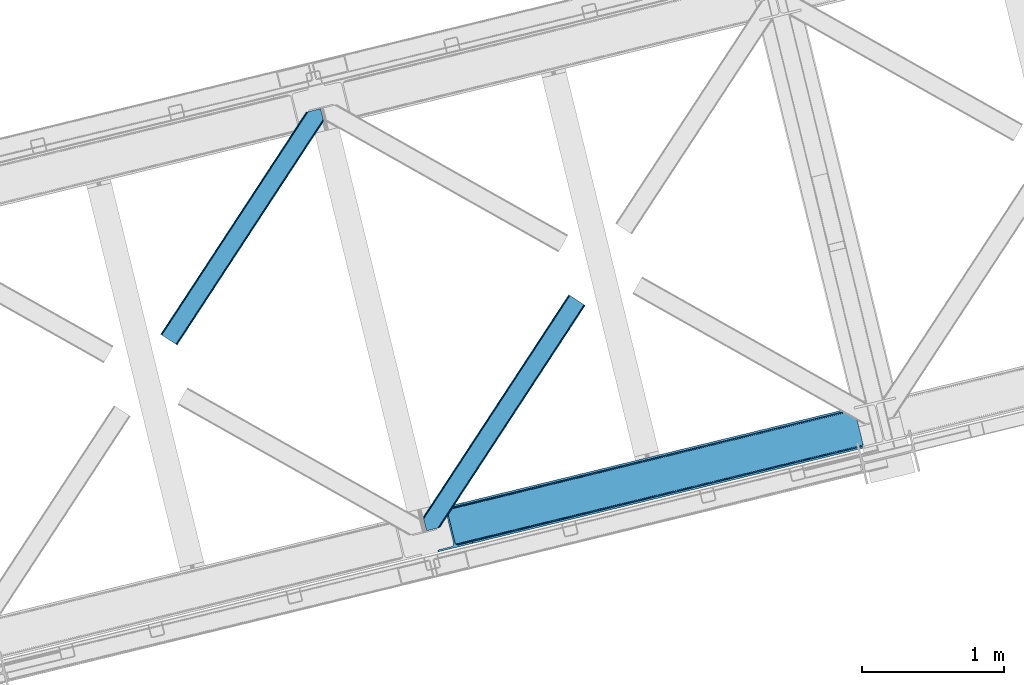
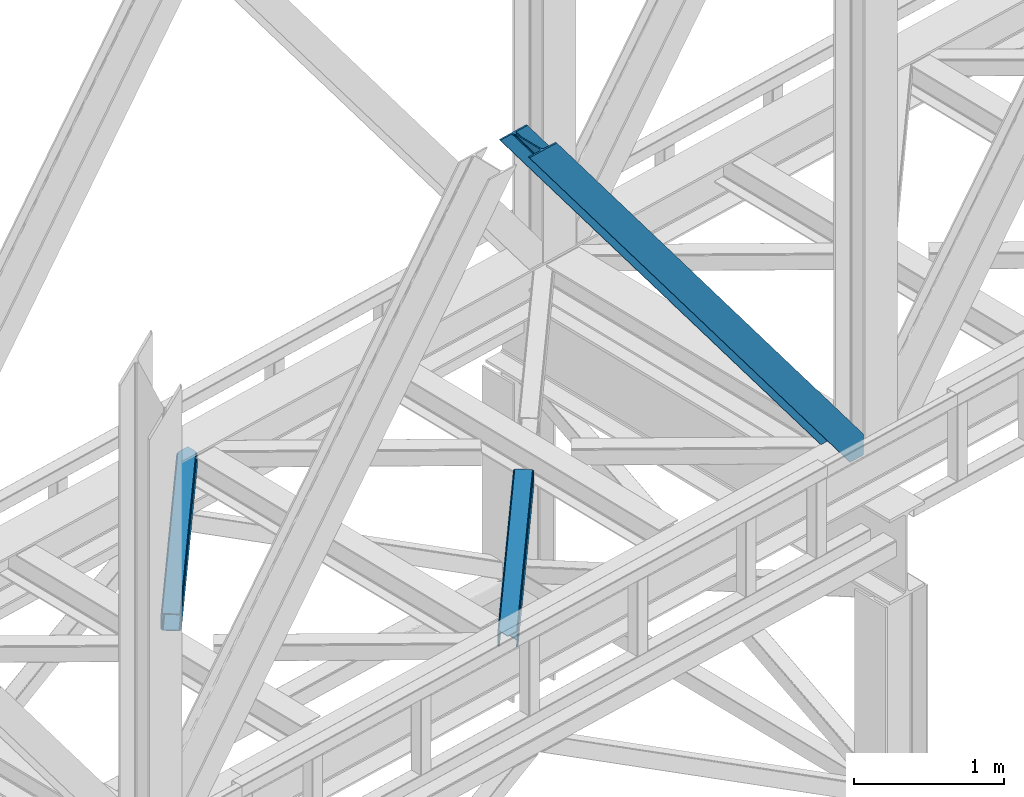
# One storey, part 47 of 93: 3 members.
"""IFC4 building model written with IfcOpenShell, lengths in millimetres."""

from ifc_helpers import new_model, entity, si_unit, converted_unit, derived_unit, direction, frame, origin, place, context, subcontext, project, spatial, triangles, type_object, element, save


model = new_model("IFC4")

# Units and contexts
model_context = context("Model", 3, precision=0.01, world=origin(), true_north=direction((6.12303176911189e-17, 1.0)))
plan_context = context("Plan", 3, precision=0.01, world=origin(), true_north=direction((6.12303176911189e-17, 1.0)))
body_context = subcontext(model_context, "Body", "Model", "MODEL_VIEW")
ifc_project = project(units=[si_unit("LENGTHUNIT", "METRE", prefix="MILLI"), si_unit("AREAUNIT", "SQUARE_METRE"), si_unit("VOLUMEUNIT", "CUBIC_METRE"), converted_unit("PLANEANGLEUNIT", "DEGREE", entity("IfcRatioMeasure", 0.0174532925199433), si_unit("PLANEANGLEUNIT", "RADIAN"), dimensions=[0, 0, 0, 0, 0, 0, 0]), si_unit("MASSUNIT", "GRAM", prefix="KILO"), derived_unit("MASSDENSITYUNIT", [(si_unit("MASSUNIT", "GRAM", prefix="KILO"), 1), (si_unit("LENGTHUNIT", "METRE"), -3)]), derived_unit("MOMENTOFINERTIAUNIT", [(si_unit("LENGTHUNIT", "METRE"), 4)]), si_unit("TIMEUNIT", "SECOND"), si_unit("FREQUENCYUNIT", "HERTZ"), si_unit("THERMODYNAMICTEMPERATUREUNIT", "DEGREE_CELSIUS"), derived_unit("THERMALTRANSMITTANCEUNIT", [(si_unit("MASSUNIT", "GRAM", prefix="KILO"), 1), (si_unit("THERMODYNAMICTEMPERATUREUNIT", "KELVIN"), -1), (si_unit("TIMEUNIT", "SECOND"), -3)]), derived_unit("VOLUMETRICFLOWRATEUNIT", [(si_unit("LENGTHUNIT", "METRE"), 3), (si_unit("TIMEUNIT", "SECOND"), -1)]), derived_unit("MASSFLOWRATEUNIT", [(si_unit("MASSUNIT", "GRAM", prefix="KILO"), 1), (si_unit("TIMEUNIT", "SECOND"), -1)]), derived_unit("ROTATIONALFREQUENCYUNIT", [(si_unit("TIMEUNIT", "SECOND"), -1)]), si_unit("ELECTRICCURRENTUNIT", "AMPERE"), si_unit("ELECTRICVOLTAGEUNIT", "VOLT"), si_unit("POWERUNIT", "WATT"), si_unit("FORCEUNIT", "NEWTON", prefix="KILO"), si_unit("ILLUMINANCEUNIT", "LUX"), si_unit("LUMINOUSFLUXUNIT", "LUMEN"), si_unit("LUMINOUSINTENSITYUNIT", "CANDELA"), derived_unit("USERDEFINED", [(si_unit("MASSUNIT", "GRAM", prefix="KILO"), -1), (si_unit("LENGTHUNIT", "METRE"), -2), (si_unit("TIMEUNIT", "SECOND"), 3), (si_unit("LUMINOUSFLUXUNIT", "LUMEN"), 1)]), derived_unit("LINEARVELOCITYUNIT", [(si_unit("LENGTHUNIT", "METRE"), 1), (si_unit("TIMEUNIT", "SECOND"), -1)]), si_unit("PRESSUREUNIT", "PASCAL"), derived_unit("USERDEFINED", [(si_unit("LENGTHUNIT", "METRE"), -2), (si_unit("MASSUNIT", "GRAM", prefix="KILO"), 1), (si_unit("TIMEUNIT", "SECOND"), -2)]), derived_unit("LINEARFORCEUNIT", [(si_unit("MASSUNIT", "GRAM", prefix="KILO"), 1), (si_unit("LENGTHUNIT", "METRE"), 1), (si_unit("TIMEUNIT", "SECOND"), -2), (si_unit("LENGTHUNIT", "METRE"), -1)]), derived_unit("PLANARFORCEUNIT", [(si_unit("MASSUNIT", "GRAM", prefix="KILO"), 1), (si_unit("LENGTHUNIT", "METRE"), 1), (si_unit("TIMEUNIT", "SECOND"), -2), (si_unit("LENGTHUNIT", "METRE"), -2)])], contexts=[model_context, plan_context])

# Site, building, storey
site_placement = place(None, origin())
site = spatial("IfcSite", under=ifc_project, at=site_placement, CompositionType="ELEMENT")
building_placement = place(site_placement, origin())
building = spatial("IfcBuilding", under=site, at=building_placement, CompositionType="ELEMENT")
storey_placement = place(building_placement, frame((0.0, 0.0, 15900.0)))
storey = spatial("IfcBuildingStorey", under=building, at=storey_placement, CompositionType="ELEMENT", Elevation=15900.0)

# Members
member_type_1 = type_object("IfcMemberType", PredefinedType="BRACE")
member_1_placement = place(storey_placement, frame((-38975.8837463379, 7966.00446166992, 3694.99929199219)))
element("IfcMember", 1, at=member_1_placement, inside=storey, type_object=member_type_1, ObjectType="Steel Vertical Brace", PredefinedType="BRACE", context=body_context, shape_type="Tessellation", body=[
    triangles([(3067.37323608399, 755.491676330566, 0.827856445310317), (3068.02901000977, 754.507434082031, 1.13248901367115), (3066.60119018555, 754.04641571045, 0.0), (3064.68037719727, 761.9255859375, 0.0), (3064.2176147461, 752.731379699707, 7.29955444335792), (3064.2176147461, 752.731379699707, 0.0), (3059.99926757813, 741.22801208496, 0.0), (3059.68998413086, 743.592402648926, 30.563250732419), (3059.80625610352, 742.210510253905, 42.2602111816377), (3059.81788330078, 745.528330993652, 0.0), (3059.81788330078, 745.528330993652, 24.1799194335908), (3059.80625610352, 742.210510253905, 171.115136718749), (3059.99926757813, 741.22801208496, 171.175598144531), (3061.30151367188, 749.56936340332, 14.6921264648408), (3061.30151367188, 749.56936340332, 0.0), (3060.72247924805, 747.995040893554, 18.3872497558586), (215.726367187504, 48.9359664916992, 3911.00081176758), (310.453143310551, 72.0269989013668, 3911.00081176758), (192.837066650391, 54.7931671142578, 3911.00081176758), (198.973901367193, 50.2783264160153, 3911.00081176758), (207.010620117188, 48.221475219726, 3911.00081176758), (189.534942626953, 61.0788299560545, 3911.00081176758), (3062.84095458985, 729.569421386718, 171.175598144531), (313.532025146487, 59.3963745117189, 3911.00081176758), (3062.84095458985, 729.569421386718, 0.0), (2945.0109375, 700.847337341308, 0.0), (69.8655029296933, 0.0, 3911.00081176758), (2941.93205566407, 713.477380371093, 0.0), (66.78662109375, 12.6300430297852, 3911.00081176758), (161.51107177735, 35.72049407959, 3911.00081176758), (3036.65650634766, 736.567831420899, 0.0), (3054.3251953125, 759.401321411132, 0.0), (3054.28798828126, 752.302336120606, 0.0), (179.17976074219, 58.5539840698239, 3911.00081176758), (179.140228271484, 51.4549987792971, 3911.00081176758), (3050.91610107422, 745.46961364746, 0.0), (175.770666503908, 44.6222763061523, 3911.00081176758), (3044.72578125, 739.944950866699, 0.0), (169.580346679693, 39.0976135253904, 3911.00081176758), (2999.1448425293, 985.772969055176, 0.0), (123.999407958989, 284.925631713867, 3911.00081176758), (2972.9510925293, 997.915251159669, 0.0), (2981.66916503906, 998.629742431641, 0.0), (106.5214050293, 297.782405090332, 3911.00081176758), (97.8056579589902, 297.06791381836, 3911.00081176758), (2989.70820922852, 996.572891235351, 0.0), (114.560449218756, 295.725553894044, 3911.00081176758), (2995.84271850586, 992.058631896972, 0.0), (120.697283935551, 291.211294555665, 3911.00081176758), (3.07888183594332, 273.977462768554, 3911.00081176758), (2878.22664184571, 974.824800109863, 0.0), (2875.14776000977, 987.454843139648, 0.0), (0.0, 286.607505798339, 3911.00081176758), (3009.50002441407, 988.297233581542, 0.0), (134.354589843751, 287.450477600097, 3911.00081176758), (143.954003906256, 306.906848144531, 3911.00081176758), (243.668847656256, 346.004461669922, 3911.00081176758), (152.020953369145, 310.283386230468, 3911.00081176758), (137.763684082034, 301.381604003906, 3911.00081176758), (134.394122314457, 294.549462890624, 3911.00081176758), (246.747729492192, 333.374418640137, 3911.00081176758), (2992.97777709962, 1016.17750854492, 171.175598144531), (2992.97777709962, 1016.17750854492, 0.0), (2995.81946411133, 1004.51891784668, 171.175598144531), (2996.0985168457, 1003.55792999267, 171.115136718749), (2996.0985168457, 1003.55792999267, 42.2602111816377), (2995.81946411133, 1004.51891784668, 0.0), (3004.85844726563, 996.247329711913, 0.0), (2997.63795776368, 1000.6174118042, 0.0), (3000.81218261719, 997.712356567382, 0.0), (3007.57921142579, 996.17582244873, 0.0), (2996.63104248047, 1002.27719421387, 30.563250732419), (2997.8007385254, 1000.74124145508, 25.1542785644524), (2999.21228027344, 998.89019165039, 18.6337463378877), (3000.81218261719, 997.712356567382, 14.6921264648408), (3004.85844726563, 996.247329711913, 7.29955444335792), (3009.05819091797, 996.424063110352, 1.13248901367115), (3008.93029174805, 995.247972106933, 0.827856445310317)], [[1, 2, 3], [3, 4, 1], [5, 6, 3], [7, 8, 9], [7, 10, 11], [11, 8, 7], [9, 12, 13], [13, 7, 9], [14, 10, 15], [10, 14, 16], [11, 10, 16], [6, 5, 15], [14, 15, 5], [3, 2, 5], [17, 18, 12], [12, 9, 17], [1, 19, 5], [19, 20, 16], [16, 14, 19], [14, 5, 19], [20, 21, 8], [8, 11, 20], [9, 8, 21], [21, 17, 9], [11, 16, 20], [5, 2, 1], [1, 4, 19], [22, 19, 4], [13, 12, 18], [23, 13, 24], [18, 24, 13], [23, 25, 7], [7, 13, 23], [24, 26, 23], [24, 27, 26], [26, 25, 23], [28, 26, 29], [27, 29, 26], [29, 30, 28], [31, 28, 30], [32, 33, 34], [35, 34, 33], [33, 36, 35], [37, 35, 36], [36, 38, 37], [39, 37, 38], [38, 31, 39], [30, 39, 31], [40, 32, 34], [34, 41, 40], [42, 43, 44], [44, 45, 42], [43, 46, 47], [47, 44, 43], [46, 48, 49], [49, 47, 46], [48, 40, 41], [41, 49, 48], [45, 50, 51], [51, 42, 45], [52, 51, 50], [50, 53, 52], [4, 54, 55], [55, 22, 4], [41, 34, 55], [37, 39, 21], [30, 27, 24], [29, 27, 30], [39, 30, 17], [34, 35, 19], [35, 37, 20], [47, 56, 44], [53, 45, 57], [45, 44, 58], [53, 50, 45], [47, 49, 59], [49, 41, 60], [55, 34, 22], [17, 21, 39], [19, 35, 20], [21, 20, 37], [19, 22, 34], [24, 17, 30], [24, 18, 17], [58, 44, 56], [59, 49, 60], [55, 60, 41], [59, 56, 47], [58, 57, 45], [57, 58, 61], [57, 52, 53], [52, 57, 62], [63, 52, 62], [64, 62, 57], [65, 64, 61], [57, 61, 64], [61, 58, 65], [66, 65, 58], [64, 67, 62], [63, 62, 67], [32, 40, 54], [46, 43, 67], [42, 52, 63], [51, 52, 42], [43, 42, 63], [40, 48, 68], [48, 46, 69], [36, 7, 38], [26, 31, 25], [31, 38, 25], [26, 28, 31], [36, 33, 10], [33, 32, 6], [10, 7, 36], [54, 40, 68], [67, 69, 46], [63, 67, 43], [48, 69, 70], [70, 68, 48], [71, 54, 68], [32, 54, 4], [10, 33, 15], [33, 6, 15], [7, 25, 38], [32, 4, 6], [3, 6, 4], [67, 72, 73], [65, 66, 64], [67, 64, 66], [66, 72, 67], [69, 74, 75], [69, 73, 74], [76, 77, 71], [71, 68, 76], [76, 68, 70], [70, 75, 76], [75, 70, 69], [73, 69, 67], [60, 78, 76], [76, 59, 60], [76, 75, 59], [75, 74, 59], [78, 77, 76], [54, 78, 60], [60, 55, 54], [73, 59, 74], [59, 73, 72], [56, 59, 72], [72, 66, 56], [58, 56, 66], [77, 78, 71], [54, 71, 78]]),
])
member_type_2 = type_object("IfcMemberType", PredefinedType="BRACE")
member_2_placement = place(storey_placement, frame((-40863.0220458984, 9423.02541046143, 3511.0000579834)))
element("IfcMember", 2, at=member_2_placement, inside=storey, type_object=member_type_2, ObjectType="Steel Horizontal Brace", PredefinedType="BRACE", context=body_context, shape_type="Tessellation", body=[
    triangles([(994.776489257813, 1564.02720794678, 0.0), (1028.82557373047, 1424.34736175537, 0.0), (14.6409667968765, 67.1040435791001, 0.0), (102.486767578128, 9.58604278564417, 0.0), (1.1162109375, 75.9604797363281, 10.8028289794929), (0.0, 76.6900863647461, 17.5000946044929), (1025.02580566407, 1642.17825164795, 17.5000946044929), (4.28811035156104, 73.8821182250977, 5.12526855468968), (990.47907714844, 1585.87703704834, 9.50058288574292), (990.041894531249, 1584.44689178467, 8.74132690429906), (989.90701904297, 1583.99226837158, 8.50064392089917), (990.762780761717, 1580.48783111572, 5.12526855468968), (1027.30938720703, 1642.73519439697, 10.8702667236357), (1027.77912597657, 1642.8503036499, 9.50058288574292), (992.604528808595, 1572.9359664917, 1.33247680664135), (9.03665771484521, 70.7724243164048, 1.33247680664135), (1025.02580566407, 1642.17825164795, 122.500662231447), (0.0, 76.6900863647461, 122.500662231447), (1026.92336425781, 1642.64101409912, 129.197927856447), (1.1162109375, 75.9604797363281, 129.197927856447), (1032.31838378906, 1643.95605010986, 134.874325561526), (4.28811035156104, 73.8821182250977, 134.874325561526), (1040.39230957031, 1645.92453460693, 138.667117309571), (9.03665771484521, 70.7724243164048, 138.667117309571), (1049.91730957032, 1648.24648590088, 139.999594116212), (14.6409667968765, 67.1040435791001, 139.999594116212), (994.874157714847, 1567.85139312744, 9.50058288574292), (994.762536621092, 1567.00725860596, 9.29478149414354), (994.650915527345, 1566.15033416748, 9.08781738281323), (994.539294433598, 1565.30619964599, 8.8831787109375), (994.748583984379, 1564.14464263916, 8.50064392089917), (1047.05701904297, 1647.54769134521, 9.50058288574292), (14.892114257811, 66.9377746582031, 8.3320495605476), (20.4964233398423, 63.2693939208984, 6.99957275390625), (997.046118164064, 1554.71498565674, 6.99957275390625), (10.1435668945342, 70.0474685668942, 12.1260040283232), (1042.27591552735, 1646.3826461792, 12.1260040283232), (1036.8808959961, 1645.06761016846, 17.8035644531265), (1034.98333740234, 1644.60601043701, 24.4996673583992), (6.97166748047312, 72.1258300781246, 17.8035644531265), (5.85545654297312, 72.8560180664063, 24.4996673583992), (1026.55129394531, 1433.65958404541, 6.99957275390625), (96.6313110351548, 13.4206924438477, 6.99957275390625), (1028.71860351563, 1424.77640533447, 8.41343994140698), (1032.83463134766, 1407.88673858643, 5.12526855468968), (1033.6903930664, 1404.38230133057, 8.50064392089917), (1030.99288330078, 1415.43860321045, 1.33247680664135), (1034.98333740234, 1644.60601043701, 115.501089477541), (5.85545654297312, 72.8560180664063, 115.501089477541), (1050.3498413086, 1648.35113067627, 131.667544555665), (1059.87484130859, 1650.67308197021, 133.000021362306), (20.4964233398423, 63.2693939208984, 133.000021362306), (14.892114257811, 66.9377746582031, 131.667544555665), (1042.27591552735, 1646.3826461792, 127.87475280762), (10.1435668945342, 70.0474685668942, 127.87475280762), (1036.8808959961, 1645.06761016846, 122.196029663086), (6.97166748047312, 72.1258300781246, 122.196029663086), (1128.10788574219, 1667.30578765869, 139.999594116212), (1128.10788574219, 1667.30578765869, 133.000021362306), (1144.33015136719, 1600.75868682861, 139.999594116212), (102.486767578128, 9.58604278564417, 139.999594116212), (1142.06052246094, 1610.06974639893, 133.000021362306), (96.6313110351548, 13.4206924438477, 133.000021362306), (1146.50211181641, 1591.84876556396, 138.667117309571), (108.091076660159, 5.91766204833948, 138.667117309571), (1148.34385986329, 1584.29690093994, 134.874325561526), (112.839624023436, 2.80738677978479, 134.874325561526), (1149.57169189453, 1579.25069732666, 129.197927856447), (116.011523437504, 0.729606628417969, 129.197927856447), (1150.00422363282, 1577.47871246338, 122.500662231447), (117.127734375004, 0.0, 122.500662231447), (1150.00422363282, 1577.47871246338, 17.5000946044929), (117.127734375004, 0.0, 17.5000946044929), (106.98416748047, 6.64203643798828, 127.87475280762), (110.156066894531, 4.56367492675781, 122.196029663086), (111.272277832031, 3.83464965820167, 115.501089477541), (102.230969238284, 9.75173034667932, 131.667544555665), (116.011523437504, 0.729606628417969, 10.8028289794929), (106.98416748047, 6.64203643798828, 12.1260040283232), (112.839624023436, 2.80738677978479, 5.12526855468968), (111.272277832031, 3.83464965820167, 24.4996673583992), (110.156066894531, 4.56367492675781, 17.8035644531265), (108.091076660159, 5.91766204833948, 1.33247680664135), (102.230969238284, 9.75173034667932, 8.3320495605476), (1147.30206298828, 1588.56175689697, 122.196029663086), (1147.73459472656, 1586.78977203369, 115.501089477541), (1146.07423095703, 1593.60912322998, 127.87475280762), (1144.23248291016, 1601.160987854, 131.667544555665), (1147.73459472656, 1586.78977203369, 24.4996673583992), (1147.21369628907, 1588.92452545166, 17.869839477542), (1149.994921875, 1577.51591949463, 16.5001556396492), (1147.10672607422, 1589.36519622803, 16.5001556396492), (1145.27427978516, 1573.10804901123, 10.8714294433594), (1034.62056884765, 1404.78809051514, 9.50058288574292), (1144.12551269531, 1572.03369598389, 9.50058288574292), (1142.79071044922, 1588.5978012085, 12.1260040283232), (1030.22548828125, 1422.81373443603, 9.50058288574292), (1029.19764404297, 1423.67182159424, 8.80643920898729), (1139.7304321289, 1590.06050262451, 9.50058288574292)], [[1, 2, 3], [4, 3, 2], [5, 6, 7], [8, 9, 10], [11, 12, 8], [5, 13, 9], [9, 8, 5], [13, 14, 9], [15, 1, 16], [3, 16, 1], [12, 15, 8], [16, 8, 15], [7, 13, 5], [17, 7, 6], [6, 18, 17], [19, 17, 20], [18, 20, 17], [21, 19, 22], [20, 22, 19], [23, 21, 24], [22, 24, 21], [25, 23, 26], [24, 26, 23], [27, 28, 9], [28, 29, 10], [29, 30, 10], [30, 31, 11], [14, 32, 27], [27, 9, 14], [33, 34, 35], [36, 33, 31], [31, 30, 36], [28, 36, 29], [28, 27, 36], [36, 30, 29], [32, 37, 27], [36, 27, 37], [35, 31, 33], [38, 39, 40], [41, 40, 39], [37, 38, 36], [40, 36, 38], [42, 35, 34], [34, 43, 42], [1, 35, 42], [31, 12, 11], [1, 31, 35], [31, 15, 12], [31, 1, 15], [2, 1, 42], [44, 2, 42], [45, 44, 46], [44, 47, 2], [44, 45, 47], [39, 48, 41], [49, 41, 48], [50, 51, 52], [52, 53, 50], [54, 50, 53], [53, 55, 54], [56, 54, 55], [55, 57, 56], [48, 56, 57], [57, 49, 48], [56, 17, 19], [50, 23, 25], [58, 51, 25], [51, 58, 59], [51, 50, 25], [54, 23, 50], [54, 56, 21], [21, 23, 54], [19, 21, 56], [39, 7, 17], [37, 14, 38], [56, 48, 17], [37, 32, 14], [39, 38, 7], [48, 39, 17], [13, 7, 38], [38, 14, 13], [60, 25, 61], [25, 60, 58], [26, 61, 25], [51, 62, 63], [51, 59, 62], [63, 52, 51], [64, 60, 61], [61, 65, 64], [66, 64, 65], [65, 67, 66], [68, 66, 67], [67, 69, 68], [70, 68, 69], [69, 71, 70], [72, 70, 71], [71, 73, 72], [69, 74, 75], [76, 73, 71], [69, 75, 71], [69, 67, 74], [75, 76, 71], [74, 67, 65], [63, 61, 26], [61, 77, 65], [77, 61, 63], [77, 74, 65], [78, 79, 80], [81, 73, 76], [73, 82, 78], [82, 73, 81], [78, 82, 79], [4, 43, 3], [83, 80, 79], [79, 84, 83], [84, 43, 4], [4, 83, 84], [55, 24, 22], [26, 52, 63], [26, 53, 52], [53, 26, 24], [55, 53, 24], [49, 18, 6], [20, 57, 55], [22, 20, 55], [57, 20, 18], [49, 57, 18], [16, 36, 8], [3, 43, 34], [34, 33, 3], [33, 36, 16], [16, 3, 33], [5, 8, 36], [6, 41, 49], [40, 6, 5], [6, 40, 41], [40, 5, 36], [85, 86, 75], [76, 75, 86], [87, 85, 74], [75, 74, 85], [88, 87, 77], [74, 77, 87], [62, 88, 63], [77, 63, 88], [86, 89, 76], [81, 76, 89], [90, 91, 92], [70, 72, 89], [72, 90, 89], [89, 86, 70], [72, 91, 90], [85, 70, 86], [68, 70, 85], [66, 85, 87], [85, 66, 68], [87, 64, 66], [88, 64, 87], [88, 62, 60], [88, 60, 64], [62, 58, 60], [62, 59, 58], [73, 78, 93], [93, 72, 73], [94, 93, 78], [94, 95, 93], [80, 45, 46], [46, 78, 80], [46, 94, 78], [47, 45, 83], [80, 83, 45], [2, 47, 4], [83, 4, 47], [93, 91, 72], [82, 81, 89], [82, 92, 96], [82, 90, 92], [84, 97, 98], [79, 96, 97], [97, 84, 79], [96, 99, 97], [43, 84, 44], [44, 42, 43], [96, 79, 82], [89, 90, 82], [96, 91, 93], [96, 92, 91], [96, 95, 99], [93, 95, 96], [99, 95, 97], [94, 97, 95]]),
])
member_type_3 = type_object("IfcMemberType", PredefinedType="BRACE")
member_3_placement = place(storey_placement, frame((-39011.7001647949, 8114.09658508301, 3511.0000579834)))
element("IfcMember", 3, at=member_3_placement, inside=storey, type_object=member_type_3, ObjectType="Steel Horizontal Brace", PredefinedType="BRACE", context=body_context, shape_type="Tessellation", body=[
    triangles([(109.770043945311, 259.950411987305, 7.52047119140843), (115.030187988283, 238.366264343263, 7.77510681152489), (114.216284179689, 239.946981811524, 8.3320495605476), (108.809637451173, 259.66263885498, 8.52041015625218), (113.637249755855, 239.860359191895, 8.52041015625218), (112.209429931638, 237.677934265136, 8.52041015625218), (91.0363037109346, 232.516621398926, 8.52041015625218), (109.537499999999, 237.026811218261, 9.50058288574292), (90.2619323730469, 232.328260803223, 9.50058288574292), (5.02062377929542, 77.405158996582, 9.50058288574292), (0.62786865234375, 95.4313842773436, 9.50058288574292), (1046.62448730469, 1651.75382995606, 6.99957275390625), (1041.02017822266, 1655.42221069336, 8.3320495605476), (116.702178955078, 231.514938354493, 6.99957275390625), (1036.27395629883, 1658.53248596192, 12.1260040283232), (3.93231811523583, 81.8758163452158, 12.1260040283232), (1033.09740600586, 1660.61026611328, 17.8035644531265), (2.70216064452688, 86.922019958497, 17.8035644531265), (1031.98352050781, 1661.34045410156, 24.4996673583992), (2.26962890625146, 88.6940048217775, 24.4996673583992), (1122.75704956055, 1601.905128479, 6.99957275390625), (146.20968017578, 110.459536743164, 6.99957275390625), (1031.98352050781, 1661.34045410156, 115.501089477541), (2.26962890625146, 88.6940048217775, 115.501089477541), (1033.09740600586, 1660.61026611328, 122.196029663086), (2.70216064452688, 86.922019958497, 122.196029663086), (1036.27395629883, 1658.53248596192, 127.87475280762), (3.93231811523583, 81.8758163452158, 127.87475280762), (1041.02017822266, 1655.42221069336, 131.667544555665), (5.77174072265188, 74.3233703613287, 131.667544555665), (1046.62448730469, 1651.75382995606, 133.000021362306), (7.94370117187646, 65.4146118164063, 133.000021362306), (1027.24194946289, 1664.44491577149, 10.8028289794929), (0.518572998043965, 95.8720550537118, 10.8691040039084), (0.0, 98.0062271118159, 17.5000946044929), (1035.16472167968, 1659.25686035156, 1.33247680664135), (112.260589599609, 249.735919189453, 1.33247680664135), (110.544415283199, 256.772117614747, 5.59500732422021), (109.077062988283, 259.839953613281, 8.31925964355469), (1030.41384887695, 1662.36713562012, 5.12526855468968), (1040.76670532226, 1655.58847961426, 0.0), (114.430224609372, 240.827160644531, 0.0), (1026.12806396484, 1665.17510375977, 17.5000946044929), (1128.61250610351, 1598.0704788208, 0.0), (148.479309082031, 101.147895812989, 0.0), (150.651269531249, 92.2391372680659, 1.33247680664135), (148.509539794919, 101.029879760742, 8.50064392089917), (152.493017578126, 84.6866912841806, 5.12526855468968), (153.346453857419, 81.1828353881838, 8.50064392089917), (1026.12806396484, 1665.17510375977, 122.500662231447), (0.0, 98.0062271118159, 122.500662231447), (1040.76670532226, 1655.58847961426, 139.999594116212), (1035.16472167968, 1659.25686035156, 138.667117309571), (3.50211181640771, 83.6350112915034, 138.667117309571), (5.674072265625, 74.7262527465818, 139.999594116212), (1030.41384887695, 1662.36713562012, 134.874325561526), (1.66036376952979, 91.1874572753904, 134.874325561526), (1027.24194946289, 1664.44491577149, 129.197927856447), (0.430206298828125, 96.2342422485353, 129.197927856447), (23.8892395019502, 0.0, 139.999594116212), (23.8892395019502, 0.0, 133.000021362306), (1128.61250610351, 1598.0704788208, 139.999594116212), (93.3361633300738, 16.9286178588873, 139.999594116212), (1122.75704956055, 1601.905128479, 133.000021362306), (83.3809570312515, 14.5020217895508, 133.000021362306), (1143.25347290039, 1588.48443603516, 122.500662231447), (1142.13958740234, 1589.21404266358, 129.197927856447), (118.225341796875, 22.9956893920898, 122.500662231447), (116.332434082033, 22.5340896606449, 129.197927856447), (1138.96536254883, 1591.29182281494, 134.874325561526), (110.935089111328, 21.2184722900392, 134.874325561526), (1134.21681518554, 1594.40267944336, 138.667117309571), (102.861163330075, 19.2499877929686, 138.667117309571), (1143.25347290039, 1588.48443603516, 17.5000946044929), (118.225341796875, 22.9956893920898, 17.5000946044929), (1142.13958740234, 1589.21404266358, 10.8028289794929), (1133.10990600586, 1595.12647247315, 12.1260040283232), (1136.28180541992, 1593.04811096192, 17.8035644531265), (1137.39801635742, 1592.31908569336, 24.4996673583992), (1138.96536254883, 1591.29182281494, 5.12526855468968), (1134.21681518554, 1594.40267944336, 1.33247680664135), (1128.35903320312, 1598.2367477417, 8.3320495605476), (1133.10990600586, 1595.12647247315, 127.87475280762), (1137.39801635742, 1592.31908569336, 115.501089477541), (1136.28180541992, 1593.04811096192, 122.196029663086), (1128.35903320312, 1598.2367477417, 131.667544555665), (92.9059570312456, 16.8239730834966, 131.667544555665), (100.979882812499, 18.7918762207037, 127.87475280762), (106.374902343749, 20.1069122314457, 122.196029663086), (108.270135498045, 20.5685119628906, 115.501089477541), (108.270135498045, 20.5685119628906, 24.4996673583992), (100.979882812499, 18.7918762207037, 12.1260040283232), (115.474346923824, 22.3248001098636, 9.50058288574292), (106.374902343749, 20.1069122314457, 17.8035644531265), (96.2011047363267, 17.6268310546875, 9.50058288574292), (115.944085693358, 22.4393280029299, 10.8702667236357), (153.060424804688, 80.2398696899409, 9.00061340332104), (152.776721191403, 79.2974853515634, 9.50058288574292), (148.711853027344, 99.8683227539068, 8.8831787109375), (148.602557373044, 99.023606872558, 9.08781738281323), (148.493261718751, 98.1678451538091, 9.29478149414354), (148.381640624997, 97.3231292724604, 9.50058288574292)], [[1, 2, 3], [4, 5, 6], [6, 7, 4], [7, 6, 8], [8, 9, 7], [9, 8, 10], [10, 11, 9], [12, 13, 3], [3, 2, 12], [2, 14, 12], [15, 16, 8], [8, 13, 15], [8, 5, 13], [16, 10, 8], [8, 6, 5], [15, 17, 18], [18, 16, 15], [17, 19, 20], [20, 18, 17], [21, 12, 14], [14, 22, 21], [19, 23, 20], [24, 20, 23], [23, 25, 24], [26, 24, 25], [25, 27, 26], [28, 26, 27], [27, 29, 28], [30, 28, 29], [29, 31, 30], [32, 30, 31], [33, 34, 35], [36, 37, 38], [33, 4, 9], [33, 1, 39], [9, 34, 33], [9, 11, 34], [4, 7, 9], [40, 38, 1], [1, 33, 40], [38, 40, 36], [36, 41, 37], [42, 37, 41], [35, 43, 33], [41, 44, 42], [45, 42, 44], [14, 42, 22], [37, 2, 38], [2, 37, 42], [38, 2, 1], [42, 14, 2], [22, 42, 45], [46, 47, 45], [47, 46, 48], [45, 47, 22], [48, 49, 47], [50, 43, 35], [35, 51, 50], [52, 53, 54], [54, 55, 52], [53, 56, 57], [57, 54, 53], [56, 58, 59], [59, 57, 56], [58, 50, 51], [51, 59, 58], [28, 57, 26], [30, 32, 55], [32, 60, 55], [32, 61, 60], [54, 30, 55], [28, 54, 57], [16, 11, 10], [28, 30, 54], [51, 35, 20], [24, 26, 51], [24, 51, 20], [57, 59, 26], [26, 59, 51], [35, 18, 20], [18, 11, 16], [11, 18, 34], [35, 34, 18], [62, 55, 63], [62, 52, 55], [55, 60, 63], [64, 32, 31], [32, 64, 65], [61, 32, 65], [66, 67, 68], [69, 68, 67], [67, 70, 69], [71, 69, 70], [70, 72, 71], [73, 71, 72], [72, 62, 73], [63, 73, 62], [74, 66, 68], [68, 75, 74], [76, 77, 78], [79, 66, 74], [76, 78, 74], [76, 80, 77], [78, 79, 74], [77, 80, 81], [21, 44, 41], [44, 82, 81], [82, 44, 21], [82, 77, 81], [67, 83, 70], [84, 66, 79], [66, 85, 67], [85, 66, 84], [67, 85, 83], [62, 64, 52], [72, 70, 83], [83, 86, 72], [86, 64, 62], [62, 72, 86], [15, 36, 40], [41, 12, 21], [41, 13, 12], [13, 41, 36], [15, 13, 36], [19, 43, 50], [33, 17, 15], [40, 33, 15], [17, 33, 43], [19, 17, 43], [53, 27, 56], [52, 64, 31], [31, 29, 52], [29, 27, 53], [53, 52, 29], [58, 56, 27], [50, 23, 19], [25, 50, 58], [50, 25, 23], [25, 58, 27], [64, 86, 87], [87, 65, 64], [86, 83, 88], [88, 87, 86], [83, 85, 89], [89, 88, 83], [85, 84, 90], [90, 89, 85], [84, 79, 90], [91, 90, 79], [89, 68, 69], [87, 73, 63], [60, 65, 63], [65, 60, 61], [65, 87, 63], [88, 73, 87], [88, 89, 71], [71, 73, 88], [69, 71, 89], [91, 75, 68], [92, 93, 94], [89, 90, 68], [92, 95, 93], [91, 94, 75], [90, 91, 68], [96, 75, 94], [94, 93, 96], [76, 74, 75], [49, 80, 97], [98, 97, 80], [49, 48, 80], [76, 96, 98], [98, 80, 76], [96, 93, 98], [44, 81, 45], [46, 45, 81], [81, 80, 46], [48, 46, 80], [75, 96, 76], [82, 21, 22], [77, 82, 47], [47, 99, 77], [77, 100, 101], [100, 77, 99], [101, 102, 77], [77, 102, 92], [95, 92, 102], [22, 47, 82], [79, 78, 91], [94, 91, 78], [78, 77, 94], [92, 94, 77], [102, 101, 98], [101, 100, 97], [100, 99, 49], [99, 47, 49], [102, 98, 93], [93, 95, 102]]),
])

save(model, "model.ifc")
